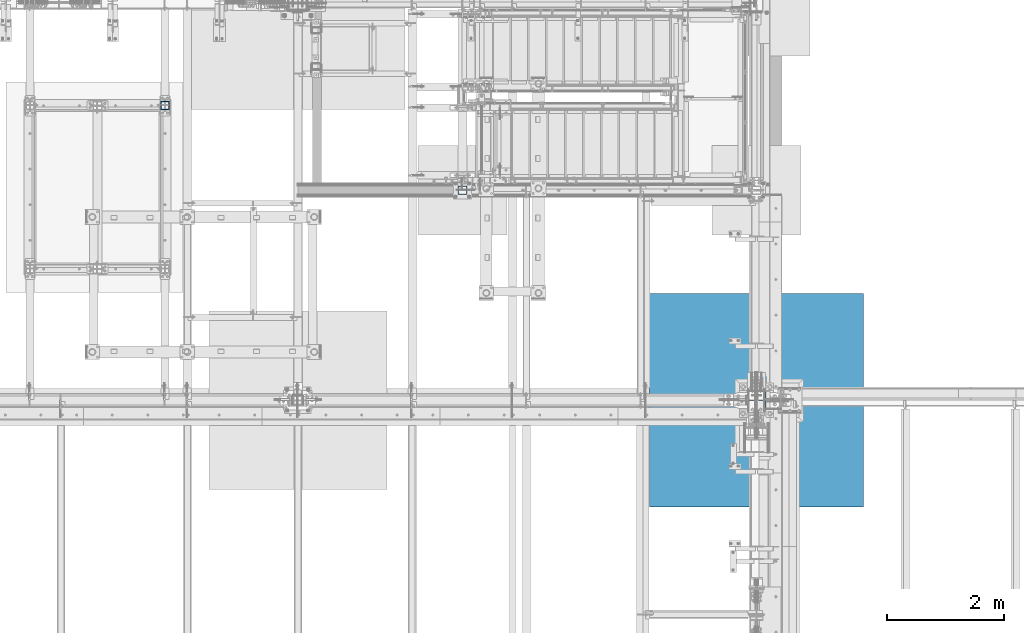
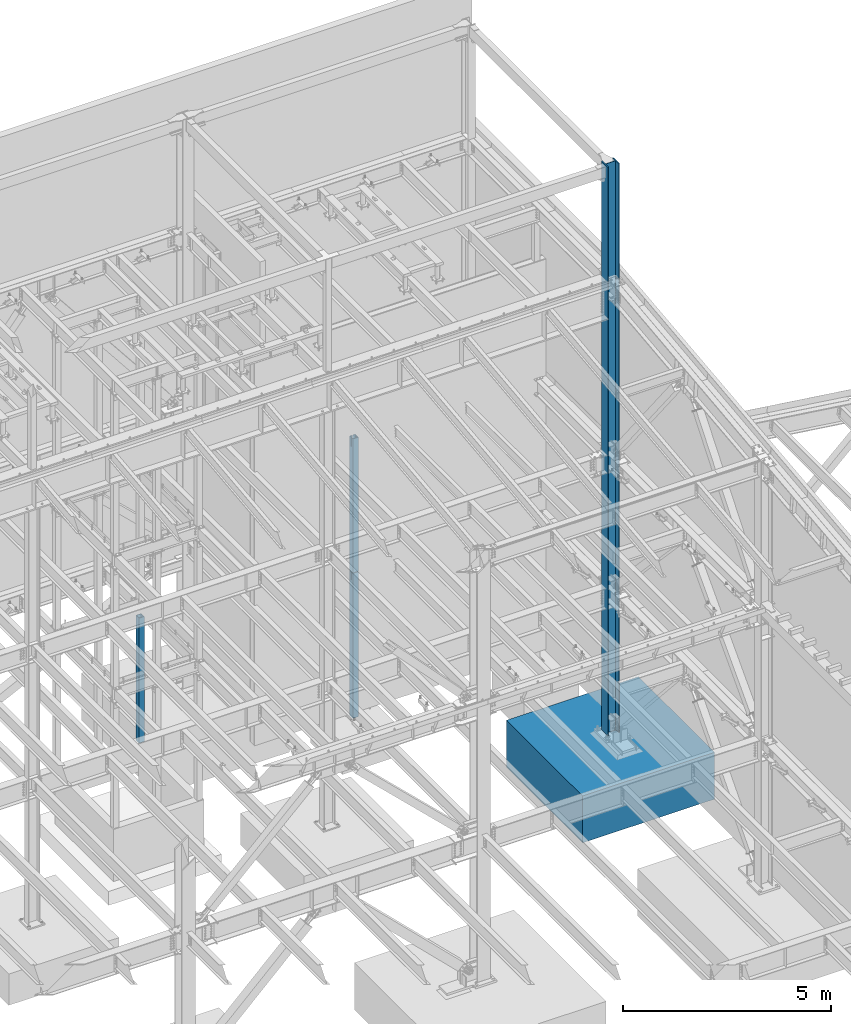
# One storey, part 371 of 1179: 5 columns, 4 elements without a shape of their own.
"""IFC2X3 building model written with IfcOpenShell, lengths in millimetres."""

from ifc_helpers import new_model, si_unit, frame, origin_with_axes, place, context, subcontext, project, spatial, faceted_brep, material, type_object, element, aggregate, save


model = new_model("IFC2X3")

# Units and contexts
model_context = context("Model", 3, precision=1e-05, world=origin_with_axes())
body_context = subcontext(model_context, "Body", "Model", "MODEL_VIEW")
ifc_project = project(units=[si_unit("LENGTHUNIT", "METRE", prefix="MILLI"), si_unit("AREAUNIT", "SQUARE_METRE"), si_unit("VOLUMEUNIT", "CUBIC_METRE"), si_unit("MASSUNIT", "GRAM", prefix="KILO"), si_unit("TIMEUNIT", "SECOND"), si_unit("PLANEANGLEUNIT", "RADIAN"), si_unit("SOLIDANGLEUNIT", "STERADIAN"), si_unit("THERMODYNAMICTEMPERATUREUNIT", "DEGREE_CELSIUS"), si_unit("LUMINOUSINTENSITYUNIT", "LUMEN")], contexts=[model_context])

# Site, building, storey
site_placement = place(None, origin_with_axes())
site = spatial("IfcSite", under=ifc_project, at=site_placement, CompositionType="ELEMENT")
building_placement = place(site_placement, origin_with_axes())
building = spatial("IfcBuilding", under=site, at=building_placement, Name="Undefined", CompositionType="ELEMENT")
storey_placement = place(building_placement, origin_with_axes())
storey = spatial("IfcBuildingStorey", under=building, at=storey_placement, Name="Undefined", CompositionType="ELEMENT", Elevation=0.0)

# Assembly, columns
assembly_1_placement = place(storey_placement, origin_with_axes())
assembly_1 = element("IfcElementAssembly", 1, at=assembly_1_placement, inside=storey, Name="COLUMN", AssemblyPlace="NOTDEFINED", PredefinedType="RIGID_FRAME")
ifc_material_1 = material()
column_type_1 = type_object("IfcColumnType", Name="HSS6X6X3/8", PredefinedType="NOTDEFINED")
column_1_placement = place(assembly_1_placement, frame((19278.6, 37985.7, 4079.875), z_axis=(0.0, 1.0, 0.0), x_axis=(0.0, 0.0, 1.0)))
column_1 = element("IfcColumn", 2, at=column_1_placement, type_object=column_type_1, material=ifc_material_1, Name="COLUMN", ObjectType="HSS6X6X3/8", context=body_context, shape_type="Brep", body=[
    faceted_brep([(3.66617592042849, 76.2000000000007, 76.1999999999971), (3.66617591870909, 76.2000000000007, -76.1999999999971), (0.0, 69.8499999999985, -69.8499999999985), (0.0, 69.8499999983651, 69.849999997823), (3.66617591870909, -76.2000000000007, -76.1999999999971), (0.0, -69.8499999999985, -69.8499999999985), (3.66617591895465, -76.2000000004264, 76.2000000004264), (0.0, -69.8499999983651, 69.849999997823), (3927.475, 66.6749999999993, 66.6750000000029), (0.0, 66.6749999999993, 66.6750000000029), (0.0, 66.6749999999993, -66.6750000000029), (3927.475, 66.6749999999993, -66.6750000000029), (3927.475, 66.6749999999993, 1.58750000000146), (3668.71249990463, 66.6749999999993, 1.58750000000146), (3666.28246014561, 66.6749999999993, 2.07086496129341), (3664.22237191153, 66.6749999999993, 3.44737191153399), (3662.84586496129, 66.6749999999993, 5.50746014561446), (3662.3625, 66.6749999999993, 7.93750009536598), (3662.84586496129, 66.6749999999993, 10.3675398543855), (3664.22237191153, 66.6749999999993, 12.427628088466), (3666.28246014561, 66.6749999999993, 13.8041350387066), (3668.71249990463, 66.6749999999993, 14.2874999999985), (3927.47500009537, 66.6749999999993, 14.2874999999985), (3668.71249990463, 76.2000000000007, 14.2874999999985), (3927.475, 76.2000000000007, 14.2874999999985), (3666.28246014561, 76.2000000000007, 13.8041350387066), (3664.22237191153, 76.2000000000007, 12.427628088466), (3662.84586496129, 76.2000000000007, 10.3675398543855), (3662.3625, 76.2000000000007, 7.93750009536598), (3662.84586496129, 76.2000000000007, 5.50746014561446), (3664.22237191153, 76.2000000000007, 3.44737191153399), (3666.28246014561, 76.2000000000007, 2.07086496129341), (3668.71249990463, 76.2000000000007, 1.58750000000146), (3927.475, 76.2000000000007, 1.58750000000146), (3927.475, -76.2000000000007, -76.1999999999971), (3927.475, -76.2000000000007, 1.58750000000146), (3668.71249990463, -76.2000000000007, 1.58750000000146), (3666.28246014561, -76.2000000000007, 2.07086496129341), (3664.22237191153, -76.2000000000007, 3.44737191153399), (3662.84586496129, -76.2000000000007, 5.50746014561446), (3662.3625, -76.2000000000007, 7.93750009536598), (3662.84586496129, -76.2000000000007, 10.3675398543855), (3664.22237191153, -76.2000000000007, 12.427628088466), (3666.28246014561, -76.2000000000007, 13.8041350387066), (3668.71249990463, -76.2000000000007, 14.2874999999985), (3927.47500009537, -76.2000000000007, 14.2874999999985), (3927.475, -76.2000000000007, 76.1999999999971), (3927.475, 76.2000000000007, -76.1999999999971), (3927.475, 76.2000000000007, 76.1999999999971), (3927.47500009537, -15.0812499999993, 76.1999999999971), (3592.51249990463, -15.0812499999993, 76.1999999999971), (3590.08246014561, -14.5978850387037, 76.1999999999971), (3588.02237191153, -13.2213780884667, 76.1999999999971), (3586.64586496129, -11.1612898543899, 76.1999999999971), (3586.1625, -8.7312500953667, 76.1999999999971), (3586.64586496129, -6.30121014561155, 76.1999999999971), (3588.02237191153, -4.24112191153472, 76.1999999999971), (3590.08246014561, -2.86461496129778, 76.1999999999971), (3592.51249990463, -2.38125000000218, 76.1999999999971), (3927.475, -2.38125000000218, 76.1999999999971), (3927.475, -2.38125000000218, 66.6750000000029), (3927.475, -66.6749999999993, 66.6750000000029), (0.0, -66.6749999999993, 66.6750000000029), (3592.51249990463, -2.38125000000218, 66.6750000000029), (3590.08246014561, -2.86461496129778, 66.6750000000029), (3588.02237191153, -4.24112191153472, 66.6750000000029), (3586.64586496129, -6.30121014561155, 66.6750000000029), (3586.1625, -8.7312500953667, 66.6750000000029), (3586.64586496129, -11.1612898543899, 66.6750000000029), (3588.02237191153, -13.2213780884667, 66.6750000000029), (3590.08246014561, -14.5978850387037, 66.6750000000029), (3592.51249990463, -15.0812499999993, 66.6750000000029), (3927.475, -15.0812499999993, 66.6750000000029), (3927.475, -66.6749999999993, 14.2874999999985), (3666.28246014561, -66.6749999999993, 13.8041350387066), (3664.22237191153, -66.6749999999993, 12.427628088466), (3662.84586496129, -66.6749999999993, 10.3675398543855), (3662.3625, -66.6749999999993, 7.93750009536598), (3662.84586496129, -66.6749999999993, 5.50746014561446), (3664.22237191153, -66.6749999999993, 3.44737191153399), (3666.28246014561, -66.6749999999993, 2.07086496129341), (3668.71249990463, -66.6749999999993, 1.58750000000146), (3927.475, -66.6749999999993, 1.58750000000146), (3927.475, -66.6749999999993, -66.6750000000029), (0.0, -66.6749999999993, -66.6750000000029), (3668.71249990463, -66.6749999999993, 14.2874999999985)], [[[0, 1, 2, 3]], [[4, 5, 2, 1]], [[6, 7, 5, 4]], [[8, 9, 10, 11, 12, 13, 14, 15, 16, 17, 18, 19, 20, 21, 22]], [[22, 21, 23, 24]], [[20, 25, 23, 21]], [[19, 26, 25, 20]], [[18, 27, 26, 19]], [[17, 28, 27, 18]], [[16, 29, 28, 17]], [[15, 30, 29, 16]], [[14, 31, 30, 15]], [[13, 32, 31, 14]], [[12, 33, 32, 13]], [[34, 35, 36, 37, 38, 39, 40, 41, 42, 43, 44, 45, 46, 6, 4]], [[47, 34, 4, 1]], [[48, 24, 23, 25, 26, 27, 28, 29, 30, 31, 32, 33, 47, 1, 0]], [[46, 49, 50, 51, 52, 53, 54, 55, 56, 57, 58, 59, 48, 0, 6]], [[8, 22, 24, 48, 59, 60]], [[61, 62, 9, 8, 60, 63, 64, 65, 66, 67, 68, 69, 70, 71, 72]], [[59, 58, 63, 60]], [[57, 64, 63, 58]], [[56, 65, 64, 57]], [[55, 66, 65, 56]], [[54, 67, 66, 55]], [[53, 68, 67, 54]], [[52, 69, 68, 53]], [[51, 70, 69, 52]], [[50, 71, 70, 51]], [[49, 72, 71, 50]], [[46, 45, 73, 61, 72, 49]], [[74, 75, 76, 77, 78, 79, 80, 81, 82, 83, 84, 62, 61, 73, 85]], [[45, 44, 85, 73]], [[43, 74, 85, 44]], [[42, 75, 74, 43]], [[41, 76, 75, 42]], [[40, 77, 76, 41]], [[39, 78, 77, 40]], [[38, 79, 78, 39]], [[37, 80, 79, 38]], [[36, 81, 80, 37]], [[35, 82, 81, 36]], [[34, 47, 33, 12, 11, 83, 82, 35]], [[10, 84, 83, 11]], [[3, 2, 5, 7], [9, 62, 84, 10]], [[0, 3, 7, 6]]]),
])
column_2_placement = place(assembly_1_placement, frame((19278.6, 37985.7, -355.6), z_axis=(0.0, 1.0, 0.0), x_axis=(0.0, 0.0, 1.0)))
column_2 = element("IfcColumn", 3, at=column_2_placement, type_object=column_type_1, material=ifc_material_1, Name="COLUMN", ObjectType="HSS6X6X3/8", context=body_context, shape_type="Brep", body=[
    faceted_brep([(4429.12500000094, -69.8499999983651, 69.8499999983687), (4425.45882407957, -76.2000000000007, 76.1999999999971), (4425.45882408129, -76.2000000000007, 14.2874999999985), (4429.125, -69.8499999999985, 14.2874999999985), (4429.12500000094, 69.8499999983651, 69.8499999983687), (4429.125, 69.8499999999985, 14.2874999999985), (4425.45882408129, 76.2000000000007, 14.2874999999985), (4425.45882407957, 76.2000000000007, 76.1999999999971), (4429.125, 69.8499999999985, 1.58750000000146), (4429.125, 69.8499999999985, -69.8499999999985), (4425.45882408129, 76.2000000000007, -76.1999999999971), (4425.45882408129, 76.2000000000007, 1.58750000000146), (4429.125, -69.8499999999985, -69.8499999999985), (4425.45882408129, -76.2000000000007, -76.1999999999971), (4429.125, -69.8499999999985, 1.58750000000146), (4425.45882408129, -76.2000000000007, 1.58750000000146), (4192.58749990463, -76.2000000000007, 1.58750000000146), (4192.58749990463, -66.6749999999993, 1.58750000000146), (4190.15746014561, -66.6749999999993, 2.07086496129341), (4190.15746014561, -76.2000000000007, 2.07086496129341), (4188.09737191153, -66.6749999999993, 3.44737191153399), (4188.09737191153, -76.2000000000007, 3.44737191153399), (4186.72086496129, -66.6749999999993, 5.50746014561446), (4186.72086496129, -76.2000000000007, 5.50746014561446), (4186.2375, -66.6749999999993, 7.93750009536598), (4186.2375, -76.2000000000007, 7.93750009536598), (4186.72086496129, -66.6749999999993, 10.3675398543855), (4186.72086496129, -76.2000000000007, 10.3675398543855), (4188.09737191153, -66.6749999999993, 12.427628088466), (4188.09737191153, -76.2000000000007, 12.427628088466), (4190.15746014561, -66.6749999999993, 13.8041350387066), (4190.15746014561, -76.2000000000007, 13.8041350387066), (4192.58749990463, -66.6749999999993, 14.2874999999985), (4192.58749990463, -76.2000000000007, 14.2874999999985), (4429.125, -66.6749999999993, 66.6750000000029), (177.8, -66.6749999999993, 66.6750000000029), (177.8, 66.6749999999993, 66.6750000000029), (4429.125, 66.6749999999993, 66.6750000000029), (4429.125, -2.38125000000218, 66.6750000000029), (4116.38749990463, -2.38125000000218, 66.6750000000029), (4113.95746014561, -2.86461496129778, 66.6750000000029), (4111.89737191153, -4.24112191153472, 66.6750000000029), (4110.5208649613, -6.30121014561155, 66.6750000000029), (4110.0375, -8.7312500953667, 66.6750000000029), (4110.5208649613, -11.1612898543899, 66.6750000000029), (4111.89737191153, -13.2213780884667, 66.6750000000029), (4113.95746014561, -14.5978850387037, 66.6750000000029), (4116.38749990463, -15.0812499999993, 66.6750000000029), (4429.125, -15.0812499999993, 66.6750000000029), (4192.58749990463, 66.6749999999993, 1.58750000000146), (4192.58749990463, 76.2000000000007, 1.58750000000146), (4190.15746014561, 76.2000000000007, 2.07086496129341), (4190.15746014561, 66.6749999999993, 2.07086496129341), (4188.09737191153, 76.2000000000007, 3.44737191153399), (4188.09737191153, 66.6749999999993, 3.44737191153399), (4186.72086496129, 76.2000000000007, 5.50746014561446), (4186.72086496129, 66.6749999999993, 5.50746014561446), (4186.2375, 76.2000000000007, 7.93750009536598), (4186.2375, 66.6749999999993, 7.93750009536598), (4186.72086496129, 76.2000000000007, 10.3675398543855), (4186.72086496129, 66.6749999999993, 10.3675398543855), (4188.09737191153, 76.2000000000007, 12.427628088466), (4188.09737191153, 66.6749999999993, 12.427628088466), (4190.15746014561, 76.2000000000007, 13.8041350387066), (4190.15746014561, 66.6749999999993, 13.8041350387066), (4192.58749990463, 76.2000000000007, 14.2874999999985), (4192.58749990463, 66.6749999999993, 14.2874999999985), (177.8, 66.6749999999993, -66.6750000000029), (4429.125, 66.6749999999993, -66.6750000000029), (4429.125, 66.6749999999993, 1.58750000000146), (4429.125, 66.6749999999993, 14.2874999999985), (177.8, -76.2000000000007, -76.1999999999971), (177.8, 76.2000000000007, -76.1999999999971), (177.8, 76.2000000000007, 76.1999999999971), (4429.125, -2.38125000000218, 69.849999997823), (4425.45882407957, -2.38125000000218, 76.1999999999971), (4116.38749990463, -2.38125000000218, 76.1999999999971), (4113.95746014561, -2.86461496129778, 76.1999999999971), (4111.89737191153, -4.24112191153472, 76.1999999999971), (4110.5208649613, -6.30121014561155, 76.1999999999971), (4110.0375, -8.7312500953667, 76.1999999999971), (4110.5208649613, -11.1612898543899, 76.1999999999971), (4111.89737191153, -13.2213780884667, 76.1999999999971), (4113.95746014561, -14.5978850387037, 76.1999999999971), (4116.38749990463, -15.0812499999993, 76.1999999999971), (4425.45882407957, -15.0812499999993, 76.1999999999971), (4429.125, -15.0812499999993, 69.849999997823), (4429.125, -66.6749999999993, 14.2874999999985), (4429.125, -66.6749999999993, 1.58750000000146), (4429.125, -66.6749999999993, -66.6750000000029), (177.8, -66.6749999999993, -66.6750000000029), (177.8, -76.2000000000007, 76.1999999999971)], [[[0, 1, 2, 3]], [[4, 5, 6, 7]], [[8, 9, 10, 11]], [[12, 13, 10, 9]], [[14, 15, 13, 12]], [[16, 17, 18, 19]], [[19, 18, 20, 21]], [[21, 20, 22, 23]], [[23, 22, 24, 25]], [[25, 24, 26, 27]], [[27, 26, 28, 29]], [[29, 28, 30, 31]], [[31, 30, 32, 33]], [[34, 35, 36, 37, 38, 39, 40, 41, 42, 43, 44, 45, 46, 47, 48]], [[49, 50, 51, 52]], [[52, 51, 53, 54]], [[54, 53, 55, 56]], [[56, 55, 57, 58]], [[58, 57, 59, 60]], [[60, 59, 61, 62]], [[62, 61, 63, 64]], [[64, 63, 65, 66]], [[37, 36, 67, 68, 69, 49, 52, 54, 56, 58, 60, 62, 64, 66, 70]], [[50, 49, 69, 8, 11]], [[71, 72, 10, 13]], [[65, 63, 61, 59, 57, 55, 53, 51, 50, 11, 10, 72, 73, 7, 6]], [[70, 66, 65, 6, 5]], [[74, 38, 37, 70, 5, 4]], [[75, 74, 4, 7]], [[76, 39, 38, 74, 75]], [[77, 40, 39, 76]], [[78, 41, 40, 77]], [[79, 42, 41, 78]], [[80, 43, 42, 79]], [[81, 44, 43, 80]], [[82, 45, 44, 81]], [[83, 46, 45, 82]], [[84, 47, 46, 83]], [[48, 47, 84, 85, 86]], [[87, 34, 48, 86, 0, 3]], [[33, 32, 87, 3, 2]], [[30, 28, 26, 24, 22, 20, 18, 17, 88, 89, 90, 35, 34, 87, 32]], [[9, 8, 69, 68, 89, 88, 14, 12]], [[67, 90, 89, 68]], [[71, 91, 73, 72], [36, 35, 90, 67]], [[84, 83, 82, 81, 80, 79, 78, 77, 76, 75, 7, 73, 91, 1, 85]], [[86, 85, 1, 0]], [[91, 71, 13, 15, 16, 19, 21, 23, 25, 27, 29, 31, 33, 2, 1]], [[88, 17, 16, 15, 14]]]),
])
aggregate(assembly_1, [column_1, column_2])

# Assembly, column
assembly_2_placement = place(storey_placement, origin_with_axes())
assembly_2 = element("IfcElementAssembly", 4, at=assembly_2_placement, inside=storey, Name="COLUMN", AssemblyPlace="NOTDEFINED", PredefinedType="RIGID_FRAME")
column_type_2 = type_object("IfcColumnType", Name="HSS6X6X5/8", PredefinedType="NOTDEFINED")
column_3_placement = place(assembly_2_placement, frame((14185.9, 39433.5, 0.0), z_axis=(0.0, 1.0, 0.0), x_axis=(0.0, 0.0, 1.0)))
column_3 = element("IfcColumn", 5, at=column_3_placement, type_object=column_type_2, material=ifc_material_1, Name="COLUMN", ObjectType="HSS6X6X5/8", context=body_context, shape_type="Brep", body=[
    faceted_brep([(0.0, 60.3250000000007, -60.3250000000007), (2.71050543121376e-20, -60.3250000000007, -60.3250000000007), (3660.775, -60.325000001314, -60.3250000000007), (3660.775, 60.3249999986838, -60.3250000000007), (2.71050543121376e-20, -60.3250000000007, 60.3250000000007), (3660.775, -60.325000001314, 60.3250000000007), (0.0, 60.3250000000007, 60.3250000000007), (3660.775, 60.3249999986838, 60.3250000000007), (6.54836185276508e-11, 76.2, -76.1999999999998), (6.54836185276508e-11, 76.2, 76.1999999999998), (3660.775, 76.1999999986838, 76.2000000000007), (3660.775, 76.1999999986838, -76.2000000000007), (-6.54836185276508e-11, -76.2, 76.1999999999998), (3660.775, -76.200000001314, 76.2000000000007), (-6.54836185276508e-11, -76.2, -76.1999999999998), (3660.775, -76.200000001314, -76.2000000000007)], [[[0, 1, 2, 3]], [[1, 4, 5, 2]], [[4, 6, 7, 5]], [[6, 0, 3, 7]], [[8, 9, 10, 11]], [[9, 12, 13, 10]], [[12, 14, 15, 13]], [[14, 8, 11, 15]], [[13, 15, 11, 10], [5, 7, 3, 2]], [[14, 12, 9, 8], [6, 4, 1, 0]]]),
])
aggregate(assembly_2, [column_3])

assembly_3_placement = place(storey_placement, origin_with_axes())
assembly_3 = element("IfcElementAssembly", 6, at=assembly_3_placement, inside=storey, Name="FOOTING", AssemblyPlace="NOTDEFINED", PredefinedType="REINFORCEMENT_UNIT")
ifc_material_2 = material(Name="CONCRETE/3000")
column_type_3 = type_object("IfcColumnType", PredefinedType="NOTDEFINED")
column_4_placement = place(assembly_3_placement, frame((24307.8, 34391.6, -1727.2), z_axis=(-1.0, 0.0, 0.0), x_axis=(0.0, 0.0, 1.0)))
column_4 = element("IfcColumn", 7, at=column_4_placement, type_object=column_type_3, material=ifc_material_2, Name="FOOTING", context=body_context, shape_type="Brep", body=[
    faceted_brep([(0.0, 1828.8, -1828.8), (0.0, 1828.8, 1828.8), (1371.6, 1828.8, 1828.8), (1371.6, 1828.8, -1828.8), (0.0, -1828.8, 1828.8), (1371.6, -1828.8, 1828.8), (0.0, -1828.8, -1828.8), (1371.6, -1828.8, -1828.8)], [[[0, 1, 2, 3]], [[1, 4, 5, 2]], [[4, 6, 7, 5]], [[6, 0, 3, 7]], [[5, 7, 3, 2]], [[6, 4, 1, 0]]]),
])
aggregate(assembly_3, [column_4])

assembly_4_placement = place(storey_placement, origin_with_axes())
assembly_4 = element("IfcElementAssembly", 8, at=assembly_4_placement, inside=storey, Name="COLUMN", AssemblyPlace="NOTDEFINED", PredefinedType="RIGID_FRAME")
ifc_material_3 = material(Name="STEEL/A992")
column_type_4 = type_object("IfcColumnType", Name="W12X96", PredefinedType="NOTDEFINED")
column_5_placement = place(assembly_4_placement, frame((24307.8, 34391.6, -355.6), z_axis=(-1.0, 0.0, 0.0), x_axis=(0.0, 0.0, 1.0)))
column_5 = element("IfcColumn", 9, at=column_5_placement, type_object=column_type_4, material=ifc_material_3, Name="COLUMN", ObjectType="W12X96", context=body_context, shape_type="Brep", body=[
    faceted_brep([(162.056584748068, -153.987500000003, 161.924999999999), (162.056584748068, 153.987500000003, 161.924999999999), (149.224999138198, 153.987500000003, 139.700000000001), (149.224999138198, 7.14375070511596, 139.700000000001), (148.995791512231, 7.1437506998991, 139.303), (148.995791512231, -7.14375000000291, 139.303), (149.224999138198, -7.14375000000291, 139.700000000001), (149.224999138198, -153.987500000003, 139.700000000001), (16814.8, 153.987500000003, -161.924999999999), (16814.8, -153.987500000003, -161.924999999999), (162.056598622603, -153.987500000003, -161.924999999999), (162.056598622603, 153.987500000003, -161.924999999999), (16814.8, -153.987500000003, -139.700000000001), (149.2254013774, -153.987500000003, -139.700000000001), (16814.8, -7.14375000000291, -139.700000000001), (149.2254013774, -7.14375000000291, -139.700000000001), (196.85, -7.14375000000291, 139.303), (196.85, 7.14375050493982, 139.303), (216.427660582082, 7.14375049639057, 132.874641068804), (216.427660582082, -7.14375000000291, 132.874641068804), (220.810373738865, 7.14375049251248, 129.878236246859), (220.810373738865, -7.14375000000291, 129.878236246859), (222.908292158607, 7.14375048631337, 125.001213099931), (222.908292158607, -7.14375000000291, 125.001213099931), (222.069634973197, 7.14375047971407, 119.758764187736), (222.069634973197, -7.14375000000291, 119.758764187736), (218.554956026489, 7.1437504747737, 115.779612472463), (218.554956026489, -7.14375000000291, 115.779612472463), (213.456195059064, 7.14375047301291, 114.299999999999), (213.456195059064, -7.14375000000291, 114.299999999999), (147.948815107339, 7.14375064105843, 114.299999999999), (139.7, -7.14375000000291, 114.299999999999), (147.948815107338, 7.1437500641041, -114.299999999999), (139.7, -7.14375000000291, -114.299999999999), (213.456195059064, 7.14375020696025, -114.299999999999), (213.456195059064, -7.14375000000291, -114.299999999999), (218.554956026488, 7.14375020498119, -115.779612472463), (218.554956026488, -7.14375000000291, -115.779612472463), (222.069634973196, 7.14375019988802, -119.758764187736), (222.069634973196, -7.14375000000291, -119.758764187736), (222.908292158606, 7.14375019325234, -125.001213099931), (222.908292158606, -7.14375000000291, -125.001213099931), (220.810373738864, 7.14375018714782, -129.878236246863), (220.810373738864, -7.14375000000291, -129.878236246863), (216.427660582081, 7.14375018345891, -132.874641068804), (216.427660582081, -7.14375000000291, -132.874641068804), (196.85, 7.14375017576094, -139.303), (196.85, -7.14375000000291, -139.303), (148.9962006887, 7.14375000474683, -139.303), (148.9962006887, -7.14375000000291, -139.303), (16814.8, 7.14375000000291, -139.700000000001), (16814.8, 153.987500000003, -139.700000000001), (149.2254013774, 153.987500000003, -139.700000000001), (149.225401377399, 7.14375000000291, -139.700000000001), (16814.8, 7.14375000000291, 139.700000000001), (16814.8, 153.987500000003, 139.700000000001), (16814.8, 153.987500000003, 161.924999999999), (16814.8, -153.987500000003, 161.924999999999), (16814.8, -153.987500000003, 139.700000000001), (16814.8, -7.14375000000291, 139.700000000001)], [[[0, 1, 2, 3, 4, 5, 6, 7]], [[8, 9, 10, 11]], [[9, 12, 13, 10]], [[12, 14, 15, 13]], [[16, 17, 18, 19]], [[19, 18, 20, 21]], [[21, 20, 22, 23]], [[23, 22, 24, 25]], [[25, 24, 26, 27]], [[27, 26, 28, 29]], [[29, 28, 30, 31]], [[32, 33, 31, 30]], [[33, 32, 34, 35]], [[35, 34, 36, 37]], [[37, 36, 38, 39]], [[39, 38, 40, 41]], [[41, 40, 42, 43]], [[43, 42, 44, 45]], [[45, 44, 46, 47]], [[47, 46, 48, 49]], [[50, 51, 52, 53]], [[10, 13, 15, 49, 48, 53, 52, 11]], [[51, 8, 11, 52]], [[50, 54, 55, 56, 57, 58, 59, 14, 12, 9, 8, 51]], [[58, 57, 0, 7]], [[59, 58, 7, 6]], [[16, 19, 21, 23, 25, 27, 29, 31, 33, 35, 37, 39, 41, 43, 45, 47, 49, 15, 14, 59, 6, 5]], [[17, 16, 5, 4]], [[54, 50, 53, 48, 46, 44, 42, 40, 38, 36, 34, 32, 30, 28, 26, 24, 22, 20, 18, 17, 4, 3]], [[55, 54, 3, 2]], [[56, 55, 2, 1]], [[57, 56, 1, 0]]]),
])
aggregate(assembly_4, [column_5])

save(model, "model.ifc")
